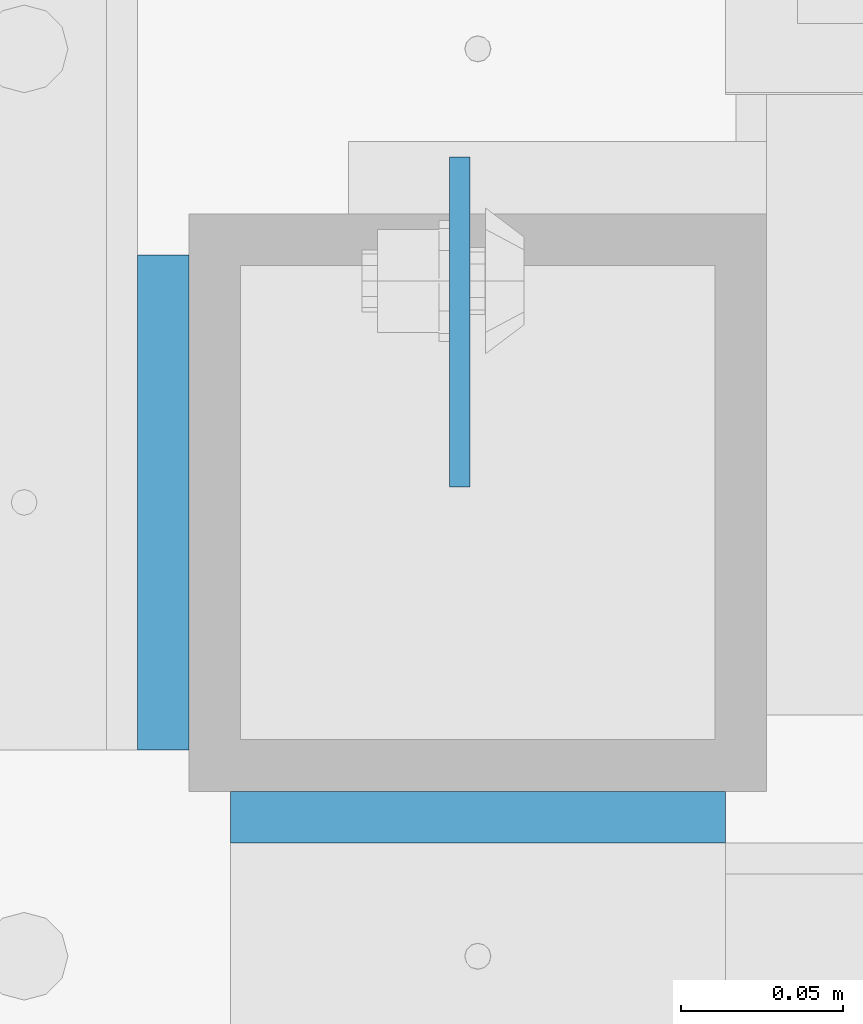
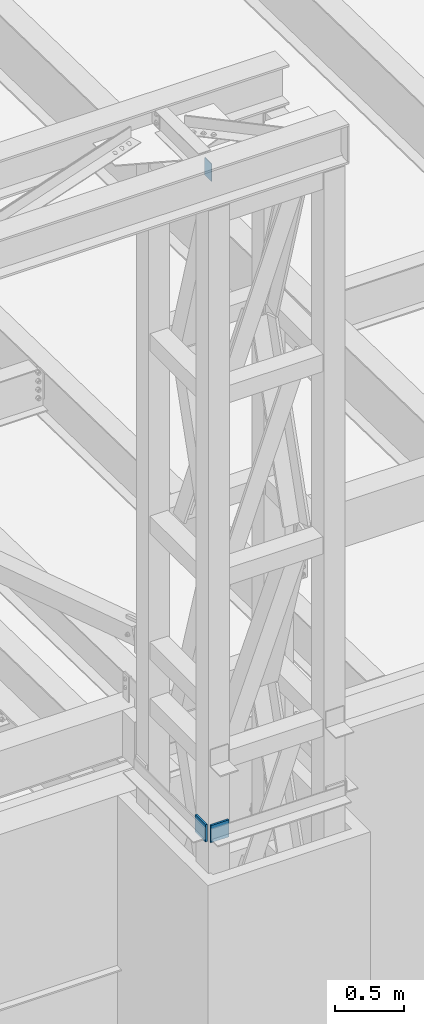
# One storey, part 1475 of 1763: 3 plates, 2 elements without a shape of their own.
"""IFC2X3 building model written with IfcOpenShell, lengths in millimetres."""

from ifc_helpers import new_model, si_unit, frame, origin_with_axes, place, context, subcontext, project, spatial, faceted_brep, material, type_object, element, aggregate, save


model = new_model("IFC2X3")

# Units and contexts
model_context = context("Model", 3, precision=1e-05, world=origin_with_axes())
body_context = subcontext(model_context, "Body", "Model", "MODEL_VIEW")
ifc_project = project(units=[si_unit("LENGTHUNIT", "METRE", prefix="MILLI"), si_unit("AREAUNIT", "SQUARE_METRE"), si_unit("VOLUMEUNIT", "CUBIC_METRE"), si_unit("MASSUNIT", "GRAM", prefix="KILO"), si_unit("TIMEUNIT", "SECOND"), si_unit("PLANEANGLEUNIT", "RADIAN"), si_unit("SOLIDANGLEUNIT", "STERADIAN"), si_unit("THERMODYNAMICTEMPERATUREUNIT", "DEGREE_CELSIUS"), si_unit("LUMINOUSINTENSITYUNIT", "LUMEN")], contexts=[model_context])

# Site, building, storey
site_placement = place(None, origin_with_axes())
site = spatial("IfcSite", under=ifc_project, at=site_placement, CompositionType="ELEMENT")
building_placement = place(site_placement, origin_with_axes())
building = spatial("IfcBuilding", under=site, at=building_placement, Name="Undefined", CompositionType="ELEMENT")
storey_placement = place(building_placement, origin_with_axes())
storey = spatial("IfcBuildingStorey", under=building, at=storey_placement, Name="Undefined", CompositionType="ELEMENT", Elevation=0.0)

# Assembly, plate
assembly_1_placement = place(storey_placement, origin_with_axes())
assembly_1 = element("IfcElementAssembly", 1, at=assembly_1_placement, inside=storey, Name="BEAM", AssemblyPlace="NOTDEFINED", PredefinedType="RIGID_FRAME")
ifc_material = material(Name="STEEL/A36")
plate_type_1 = type_object("IfcPlateType", PredefinedType="NOTDEFINED")
plate_1_placement = place(assembly_1_placement, frame((-47741.1086492629, -15447.9648088076, 18783.3), z_axis=(0.0, 1.0, 0.0), x_axis=(0.0, 0.0, -1.0)))
plate_1 = element("IfcPlate", 2, at=plate_1_placement, type_object=plate_type_1, material=ifc_material, Name="PLATE", context=body_context, shape_type="Brep", body=[
    faceted_brep([(1.81898940354586e-12, -3.17500000000291, 0.0), (0.0, -3.17499999999927, 101.599998474121), (0.0, 3.17499999999927, 101.599998474121), (-1.81898940354586e-12, 3.17499999997381, 0.0), (152.399993896484, -3.17499999999927, 101.599998474121), (152.399993896484, 3.17499999999927, 101.599998474121), (152.399993896484, -3.17500000000291, 0.0), (152.399993896484, 3.17500000000291, 0.0)], [[[0, 1, 2, 3]], [[1, 4, 5, 2]], [[4, 6, 7, 5]], [[6, 0, 3, 7]], [[5, 7, 3, 2]], [[6, 4, 1, 0]]]),
])
aggregate(assembly_1, [plate_1])

# Assembly, plates
assembly_2_placement = place(storey_placement, origin_with_axes())
assembly_2 = element("IfcElementAssembly", 3, at=assembly_2_placement, inside=storey, Name="FRAME", AssemblyPlace="NOTDEFINED", PredefinedType="RIGID_FRAME")
plate_type_2 = type_object("IfcPlateType", PredefinedType="NOTDEFINED")
plate_2_placement = place(assembly_2_placement, frame((-47832.3898997267, -15528.9272094127, 12979.3999938965), z_axis=(0.0, 0.0, -1.0), x_axis=(0.0, 1.0, 0.0)))
plate_2 = element("IfcPlate", 4, at=plate_2_placement, type_object=plate_type_2, material=ifc_material, Name="PLATE", context=body_context, shape_type="Brep", body=[
    faceted_brep([(-7.27595761418343e-12, -7.9375, 0.0), (7.27595761418343e-12, -7.9375, 152.399993896484), (7.27595761418343e-12, 7.9375, 152.399993896484), (-7.27595761418343e-12, 7.9375, 0.0), (152.399993896484, -7.9375, 152.399993896484), (152.399993896484, 7.9375, 152.399993896484), (152.399993896484, -7.9375, -1.81898940354586e-12), (152.399993896484, 7.9375, -1.81898940354586e-12)], [[[0, 1, 2, 3]], [[1, 4, 5, 2]], [[4, 6, 7, 5]], [[6, 0, 3, 7]], [[5, 7, 3, 2]], [[6, 4, 1, 0]]]),
])
plate_3_placement = place(assembly_2_placement, frame((-47811.7523997267, -15549.5647094127, 12827.0), z_axis=(1.0, 0.0, 0.0), x_axis=(0.0, 0.0, 1.0)))
plate_3 = element("IfcPlate", 5, at=plate_3_placement, type_object=plate_type_2, material=ifc_material, Name="PLATE", context=body_context, shape_type="Brep", body=[
    faceted_brep([(-7.27595761418343e-12, -7.9375, 0.0), (7.27595761418343e-12, -7.9375, 152.399993896484), (7.27595761418343e-12, 7.9375, 152.399993896484), (-7.27595761418343e-12, 7.9375, 0.0), (152.399993896484, -7.9375, 152.399993896484), (152.399993896484, 7.9375, 152.399993896484), (152.399993896484, -7.9375, -1.81898940354586e-12), (152.399993896484, 7.9375, -1.81898940354586e-12)], [[[0, 1, 2, 3]], [[1, 4, 5, 2]], [[4, 6, 7, 5]], [[6, 0, 3, 7]], [[5, 7, 3, 2]], [[6, 4, 1, 0]]]),
])
aggregate(assembly_2, [plate_2, plate_3])

save(model, "model.ifc")
